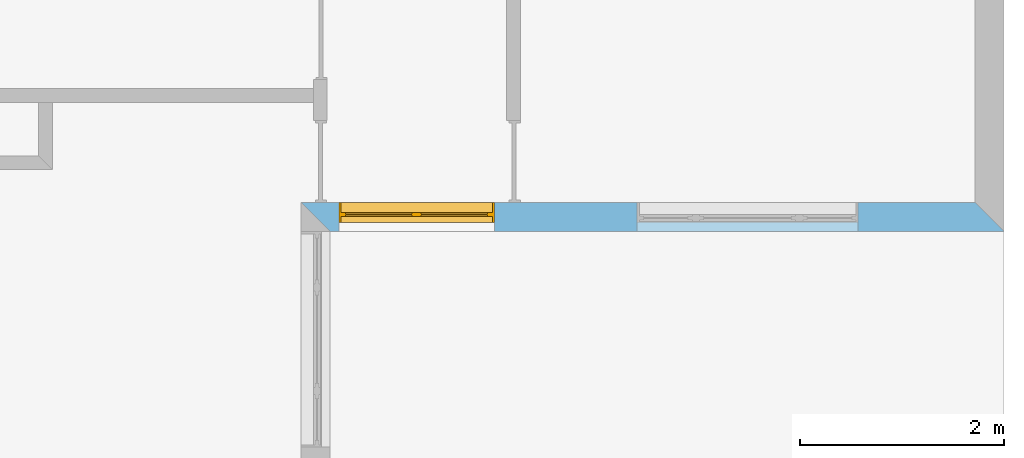
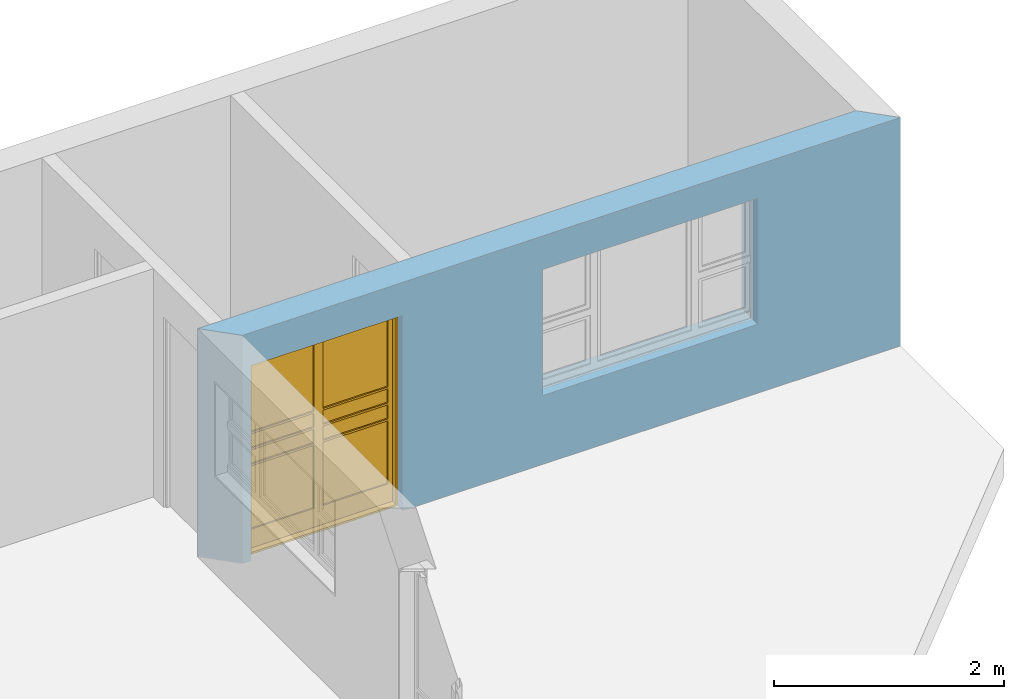
# One storey, part 12 of 15: 1 window, 2 openings, plus 1 element that does not belong to this part.
"""IFC4 building model written with IfcOpenShell, lengths in millimetres."""

from ifc_helpers import new_model, entity, si_unit, converted_unit, frame, origin_with_axes, origin_2d_with_axis, place, context, subcontext, project, spatial, line, indexed_curve, outline, extrude, clip, halfspace, polygons, source, transform, mapped, material, layer, layer_set, layer_usage, type_object, type_shapes, element, fill, save


model = new_model("IFC4")

# Units and contexts
model_context = context("Model", 3, precision=1e-05, world=origin_with_axes())
plan_context = context("Plan", 2, precision=1e-05, world=origin_2d_with_axis())
body_context = subcontext(model_context, "Body", "Model", "MODEL_VIEW")
ifc_project = project(units=[si_unit("VOLUMEUNIT", "CUBIC_METRE"), si_unit("LENGTHUNIT", "METRE", prefix="MILLI"), converted_unit("PLANEANGLEUNIT", "degree", entity("IfcReal", 0.0174532925199433), si_unit("PLANEANGLEUNIT", "RADIAN"), dimensions=[0, 0, 0, 0, 0, 0, 0]), si_unit("AREAUNIT", "SQUARE_METRE")], contexts=[model_context, plan_context])

# Site, building, storey
site_placement = place(None, origin_with_axes())
site = spatial("IfcSite", under=ifc_project, at=site_placement)
building_placement = place(site_placement, origin_with_axes())
building = spatial("IfcBuilding", under=site, at=building_placement, Name="Building")
storey_placement = place(building_placement, origin_with_axes())
storey = spatial("IfcBuildingStorey", under=building, at=storey_placement, Name="EXISTING")

# Wall, openings, window
ifc_material = material()
ifc_layer = layer(ifc_material, 285.0, Name="brick")
ifc_layer_set = layer_set([ifc_layer])
ifc_layer_usage = layer_usage(ifc_layer_set, "AXIS2", "POSITIVE", 0.0)
wall_type = type_object("IfcWallType", Name="285mm Wall", PredefinedType="STANDARD", material=ifc_layer_set)
wall_placement = place(storey_placement, frame((13209.1217041016, 2256.66809082031, 0.0), z_axis=(0.0, 0.0, 1.0), x_axis=(0.999999999999993, 1.19209282445353e-07, 0.0)))
wall = element("IfcWall", 1, at=wall_placement, inside=storey, type_object=wall_type, material=ifc_layer_usage, Name="Wall", context=body_context, shape_type="Clipping", body=[
    clip(clip(extrude(outline(indexed_curve([(0.0, 0.0), (0.0, 285.0), (6894.99959678732, 285.0), (6894.99959678732, 0.0), (0.0, 0.0)], self_intersect=False)), origin_with_axes(), (0.0, 0.0, 1.0), 2425.00019073486), halfspace(frame((284.999847412109, 0.0, 0.0), z_axis=(-0.70710676908493, -0.70710676908493, 0.0), x_axis=(-0.707106781186547, 0.707106781186547, 0.0)), False)), halfspace(frame((6894.99950408936, 0.0, 0.0), z_axis=(0.70710676908493, 0.70710676908493, 0.0), x_axis=(0.707106781186547, -0.707106781186547, 0.0)), False)),
])
shared_shape_1 = source(origin_with_axes(), body_context, "Body", "SweptSolid", [
    extrude(outline(indexed_curve([(0.0, 0.0), (2165.00048828125, 0.0), (2165.00048828125, 1340.00048828125), (0.0, 1340.00048828125)], segments=[line(1, 2, 3, 4, 1)])), frame((-5.96046390910487e-07, -600.0, 0.0), z_axis=(0.0, -1.0, 0.0), x_axis=(1.0, 0.0, 0.0)), (0.0, 0.0, -1.0), 1200.0),
])
opening_1_placement = place(wall_placement, frame((5461.99893951417, 136.110782623295, 730.000019073486), z_axis=(0.0, 0.0, 1.0), x_axis=(-0.999999999999989, 1.50995802528085e-07, 0.0)))
element("IfcOpeningElement", 2, at=opening_1_placement, cuts=wall, Name="Opening", PredefinedType="OPENING", context=body_context, shape_type="MappedRepresentation", body=[
    mapped(shared_shape_1, transform((0.0, 0.0, 0.0), x_axis=(1.0, 0.0, 0.0), y_axis=(0.0, 1.0, 0.0), z_axis=(0.0, 0.0, 1.0), scale=1.0)),
])
shared_shape_2 = source(origin_with_axes(), body_context, "Body", "SweptSolid", [
    extrude(outline(indexed_curve([(0.0, 0.0), (1525.00244140625, 0.0), (1525.00244140625, 2075.0029296875), (0.0, 2075.0029296875)], segments=[line(1, 2, 3, 4, 1)])), frame((1.19209282445354e-07, -600.0, 0.0), z_axis=(0.0, -1.0, 0.0), x_axis=(1.0, 0.0, 0.0)), (0.0, 0.0, -1.0), 1200.0),
])
opening_2_placement = place(wall_placement, frame((1895.00141143799, -33.8461399078334, 0.0), z_axis=(0.0, 0.0, 1.0), x_axis=(-0.999999999999989, 1.50995802528085e-07, 0.0)))
opening_2 = element("IfcOpeningElement", 3, at=opening_2_placement, cuts=wall, PredefinedType="OPENING", context=body_context, shape_type="MappedRepresentation", body=[
    mapped(shared_shape_2, transform((0.0, 0.0, 0.0), x_axis=(1.0, 0.0, 0.0), y_axis=(0.0, 1.0, 0.0), z_axis=(0.0, 0.0, 1.0), scale=1.0)),
])
window_type = type_object("IfcWindowType", Name="Ex.1525x2075", PartitioningType="NOTDEFINED", PredefinedType="WINDOW")
shared_shape_3 = source(origin_with_axes(), body_context, "Body", "Tessellation", [
    polygons([(1525.00061035156, -116.923126220703, 0.0), (1525.00061035156, -116.923126220703, 19.999979019165), (0.000119209282274824, -116.923126220703, 0.0), (0.000119209282274824, -116.923126220703, 19.999979019165), (1525.00061035156, 83.0769729614258, 0.0), (1525.00061035156, 83.0769729614258, 19.999979019165), (0.000119209282274824, 83.0768508911133, 0.0), (0.000119209282274824, 83.0768508911133, 19.999979019165), (0.00202655768953264, -116.923126220703, 19.999979019165), (20.0024833679199, -116.923126220703, 19.999979019165), (0.00202655768953264, -116.923126220703, 2055.00317382812), (20.0024833679199, -116.923126220703, 2055.00317382812), (0.00202655768953264, 83.0769729614258, 19.999979019165), (20.0024833679199, 83.0769729614258, 19.999979019165), (0.00202655768953264, 83.0768508911133, 2055.00317382812), (20.0024833679199, 83.0768508911133, 2055.00317382812), (1505.00207519531, -116.923126220703, 19.999979019165), (1525.00256347656, -116.923126220703, 19.999979019165), (1505.00207519531, -116.923126220703, 2055.00317382812), (1525.00256347656, -116.923126220703, 2055.00317382812), (1505.00207519531, 83.0769729614258, 19.999979019165), (1525.00256347656, 83.0769729614258, 19.999979019165), (1505.00207519531, 83.0768508911133, 2055.00317382812), (1525.00256347656, 83.0768508911133, 2055.00317382812), (1525.00061035156, -116.923126220703, 2055.00317382812), (1525.00061035156, -116.923126220703, 2075.00317382812), (0.000119209282274824, -116.923126220703, 2055.00317382812), (0.000119209282274824, -116.923126220703, 2075.00317382812), (1525.00061035156, 83.0769729614258, 2055.00317382812), (1525.00061035156, 83.0769729614258, 2075.00317382812), (0.000119209282274824, 83.0768508911133, 2055.00317382812), (0.000119209282274824, 83.0768508911133, 2075.00317382812), (65.0006484985352, -16.9231052398682, 2010.00390625), (20.0005760192871, -16.9231052398682, 2010.00390625), (65.0006484985352, -16.9231052398682, 220.002532958984), (20.0005760192871, -16.9231052398682, 220.002532958984), (65.0006484985352, 23.0769119262695, 2010.00390625), (20.0005760192871, 23.0769119262695, 2010.00390625), (65.0006484985352, 23.0769119262695, 220.002532958984), (20.0005760192871, 23.0769119262695, 220.002532958984), (762.500854492188, -16.9229869842529, 20.0024833679199), (762.500854492188, -16.9229869842529, 220.00146484375), (20.0005760192871, -16.9231052398682, 20.0034370422363), (20.0005760192871, -16.9231052398682, 220.002410888672), (762.500854492188, 23.0770320892334, 20.0024833679199), (762.500854492188, 23.0770320892334, 220.00146484375), (20.0005760192871, 23.0769119262695, 20.0034370422363), (20.0005760192871, 23.0769119262695, 220.002410888672), (1505.00109863281, -16.9231052398682, 2010.00366210938), (1460.001953125, -16.9231052398682, 2010.00366210938), (1505.00109863281, -16.9231052398682, 220.002288818359), (1460.001953125, -16.9231052398682, 220.002288818359), (1505.00109863281, 23.0769119262695, 2010.00366210938), (1460.001953125, 23.0769119262695, 2010.00366210938), (1505.00109863281, 23.0769119262695, 220.002288818359), (1460.001953125, 23.0769119262695, 220.002288818359), (762.502746582031, -16.9231052398682, 2010.00341796875), (717.503601074219, -16.9231052398682, 2010.00341796875), (762.502746582031, -16.9231052398682, 220.002410888672), (717.503601074219, -16.9231052398682, 220.002410888672), (762.502746582031, 23.0769119262695, 2010.00341796875), (717.503601074219, 23.0769119262695, 2010.00341796875), (762.502746582031, 23.0769119262695, 220.002410888672), (717.503601074219, 23.0769119262695, 220.002410888672), (807.499938964844, -16.9231052398682, 2010.00341796875), (762.501770019531, -16.9231052398682, 2010.00341796875), (807.499938964844, -16.9231052398682, 220.002410888672), (762.501770019531, -16.9231052398682, 220.002410888672), (807.499938964844, 23.0769119262695, 2010.00341796875), (762.501770019531, 23.0769119262695, 2010.00341796875), (807.499938964844, 23.0769119262695, 220.002410888672), (762.501770019531, 23.0769119262695, 220.002410888672), (1505.00109863281, -16.9229869842529, 20.0024833679199), (1505.00109863281, -16.9229869842529, 220.00146484375), (762.502746582031, -16.9231052398682, 20.0034370422363), (762.502746582031, -16.9231052398682, 220.002410888672), (1505.00109863281, 23.0770320892334, 20.0024833679199), (1505.00109863281, 23.0770320892334, 220.00146484375), (762.502746582031, 23.0769119262695, 20.0034370422363), (762.502746582031, 23.0769119262695, 220.002410888672), (762.500854492188, -16.9229869842529, 2010.00268554688), (762.500854492188, -16.9229869842529, 2055.00244140625), (20.0005760192871, -16.9231052398682, 2010.00366210938), (20.0005760192871, -16.9231052398682, 2055.00317382812), (762.500854492188, 23.0770320892334, 2010.00268554688), (762.500854492188, 23.0770320892334, 2055.00244140625), (20.0005760192871, 23.0769119262695, 2010.00366210938), (20.0005760192871, 23.0769119262695, 2055.00317382812), (1505.00109863281, -16.9229869842529, 2010.00268554688), (1505.00109863281, -16.9229869842529, 2055.00244140625), (762.502746582031, -16.9231052398682, 2010.00366210938), (762.502746582031, -16.9231052398682, 2055.00317382812), (1505.00109863281, 23.0770320892334, 2010.00268554688), (1505.00109863281, 23.0770320892334, 2055.00244140625), (762.502746582031, 23.0769119262695, 2010.00366210938), (762.502746582031, 23.0769119262695, 2055.00317382812), (717.500732421875, -16.9229869842529, 1230.00207519531), (717.500732421875, -16.9229869842529, 1250.00158691406), (64.9987411499023, -16.9231052398682, 1230.00244140625), (64.9987411499023, -16.9231052398682, 1250.00207519531), (717.500732421875, 23.0770320892334, 1230.00207519531), (717.500732421875, 23.0770320892334, 1250.00158691406), (64.9987411499023, 23.0769119262695, 1230.00244140625), (64.9987411499023, 23.0769119262695, 1250.00207519531), (1460.0009765625, -16.9229869842529, 1230.00207519531), (1460.0009765625, -16.9229869842529, 1250.00158691406), (807.499938964844, -16.9231052398682, 1230.00244140625), (807.499938964844, -16.9231052398682, 1250.00207519531), (1460.0009765625, 23.0770320892334, 1230.00207519531), (1460.0009765625, 23.0770320892334, 1250.00158691406), (807.499938964844, 23.0769119262695, 1230.00244140625), (807.499938964844, 23.0769119262695, 1250.00207519531), (717.500732421875, -16.9229869842529, 1060.00219726562), (717.500732421875, -16.9229869842529, 1080.00158691406), (64.9987411499023, -16.9231052398682, 1060.00244140625), (64.9987411499023, -16.9231052398682, 1080.00207519531), (717.500732421875, 23.0770320892334, 1060.00219726562), (717.500732421875, 23.0770320892334, 1080.00158691406), (64.9987411499023, 23.0769119262695, 1060.00244140625), (64.9987411499023, 23.0769119262695, 1080.00207519531), (1460.0009765625, -16.9229869842529, 1060.00219726562), (1460.0009765625, -16.9229869842529, 1080.00158691406), (807.499938964844, -16.9231052398682, 1060.00244140625), (807.499938964844, -16.9231052398682, 1080.00207519531), (1460.0009765625, 23.0770320892334, 1060.00219726562), (1460.0009765625, 23.0770320892334, 1080.00158691406), (807.499938964844, 23.0769119262695, 1060.00244140625), (807.499938964844, 23.0769119262695, 1080.00207519531), (717.500732421875, -16.9229869842529, 890.002197265625), (717.500732421875, -16.9229869842529, 910.001708984375), (64.9987411499023, -16.9231052398682, 890.00244140625), (64.9987411499023, -16.9231052398682, 910.002197265625), (717.500732421875, 23.0770320892334, 890.002197265625), (717.500732421875, 23.0770320892334, 910.001708984375), (64.9987411499023, 23.0769119262695, 890.00244140625), (64.9987411499023, 23.0769119262695, 910.002197265625), (1460.0009765625, -16.9229869842529, 890.002197265625), (1460.0009765625, -16.9229869842529, 910.001708984375), (807.499938964844, -16.9231052398682, 890.00244140625), (807.499938964844, -16.9231052398682, 910.002197265625), (1460.0009765625, 23.0770320892334, 890.002197265625), (1460.0009765625, 23.0770320892334, 910.001708984375), (807.499938964844, 23.0769119262695, 890.00244140625), (807.499938964844, 23.0769119262695, 910.002197265625), (717.501708984375, -1.92306184768677, 2010.00341796875), (65.0006484985352, -1.92306184768677, 2010.00341796875), (717.500732421875, -1.92306184768677, 1250.00207519531), (65.0006484985352, -1.92306184768677, 1250.00207519531), (717.501708984375, 8.07692813873291, 2010.00341796875), (65.0006484985352, 8.07692813873291, 2010.00341796875), (717.500732421875, 8.07692813873291, 1250.00207519531), (65.0006484985352, 8.07692813873291, 1250.00207519531), (717.501708984375, -1.92306184768677, 890.001953125), (65.0006484985352, -1.92306184768677, 890.001953125), (717.500732421875, -1.92306184768677, 220.001998901367), (65.0006484985352, -1.92306184768677, 220.002059936523), (717.501708984375, 8.07692813873291, 890.001953125), (65.0006484985352, 8.07692813873291, 890.001953125), (717.500732421875, 8.07692813873291, 220.001998901367), (65.0006484985352, 8.07692813873291, 220.002059936523), (717.501708984375, -1.92306184768677, 1230.001953125), (65.0006484985352, -1.92306184768677, 1230.001953125), (717.500732421875, -1.92306184768677, 1080.00158691406), (65.0006484985352, -1.92306184768677, 1080.00158691406), (717.501708984375, 8.07692813873291, 1230.001953125), (65.0006484985352, 8.07692813873291, 1230.001953125), (717.500732421875, 8.07692813873291, 1080.00158691406), (65.0006484985352, 8.07692813873291, 1080.00158691406), (1460.0009765625, -1.92306184768677, 2010.00341796875), (807.499938964844, -1.92306184768677, 2010.00341796875), (1460.0009765625, -1.92306184768677, 1250.00207519531), (807.499938964844, -1.92306184768677, 1250.00207519531), (1460.0009765625, 8.07692813873291, 2010.00341796875), (807.499938964844, 8.07692813873291, 2010.00341796875), (1460.0009765625, 8.07692813873291, 1250.00207519531), (807.499938964844, 8.07692813873291, 1250.00207519531), (1460.0009765625, -1.92306184768677, 890.001953125), (807.499938964844, -1.92306184768677, 890.001953125), (1460.0009765625, -1.92306184768677, 220.001998901367), (807.499938964844, -1.92306184768677, 220.002059936523), (1460.0009765625, 8.07692813873291, 890.001953125), (807.499938964844, 8.07692813873291, 890.001953125), (1460.0009765625, 8.07692813873291, 220.001998901367), (807.499938964844, 8.07692813873291, 220.002059936523), (1460.0009765625, -1.92306184768677, 1230.001953125), (807.499938964844, -1.92306184768677, 1230.001953125), (1460.00012207031, -1.92306184768677, 1080.00158691406), (807.499938964844, -1.92306184768677, 1080.00158691406), (1460.0009765625, 8.07692813873291, 1230.001953125), (807.499938964844, 8.07692813873291, 1230.001953125), (1460.00012207031, 8.07692813873291, 1080.00158691406), (807.499938964844, 8.07692813873291, 1080.00158691406), (717.501708984375, -1.92306184768677, 1060.00256347656), (65.0006484985352, -1.92306184768677, 1060.00256347656), (717.500732421875, -1.92306184768677, 910.002197265625), (65.0006484985352, -1.92306184768677, 910.002197265625), (717.501708984375, 8.07692813873291, 1060.00256347656), (65.0006484985352, 8.07692813873291, 1060.00256347656), (717.500732421875, 8.07692813873291, 910.002197265625), (65.0006484985352, 8.07692813873291, 910.002197265625), (1460.0009765625, -1.92306184768677, 1060.00256347656), (807.499938964844, -1.92306184768677, 1060.00256347656), (1460.00012207031, -1.92306184768677, 910.002197265625), (807.499938964844, -1.92306184768677, 910.002197265625), (1460.0009765625, 8.07692813873291, 1060.00256347656), (807.499938964844, 8.07692813873291, 1060.00256347656), (1460.00012207031, 8.07692813873291, 910.002197265625), (807.499938964844, 8.07692813873291, 910.002197265625)], [[[1, 2, 4, 3]], [[3, 4, 8, 7]], [[7, 8, 6, 5]], [[5, 6, 2, 1]], [[3, 7, 5, 1]], [[8, 4, 2, 6]], [[9, 10, 12, 11]], [[11, 12, 16, 15]], [[15, 16, 14, 13]], [[13, 14, 10, 9]], [[11, 15, 13, 9]], [[16, 12, 10, 14]], [[17, 18, 20, 19]], [[19, 20, 24, 23]], [[23, 24, 22, 21]], [[21, 22, 18, 17]], [[19, 23, 21, 17]], [[24, 20, 18, 22]], [[25, 26, 28, 27]], [[27, 28, 32, 31]], [[31, 32, 30, 29]], [[29, 30, 26, 25]], [[27, 31, 29, 25]], [[32, 28, 26, 30]], [[33, 34, 36, 35]], [[35, 36, 40, 39]], [[39, 40, 38, 37]], [[37, 38, 34, 33]], [[35, 39, 37, 33]], [[40, 36, 34, 38]], [[41, 42, 44, 43]], [[43, 44, 48, 47]], [[47, 48, 46, 45]], [[45, 46, 42, 41]], [[43, 47, 45, 41]], [[48, 44, 42, 46]], [[49, 50, 52, 51]], [[51, 52, 56, 55]], [[55, 56, 54, 53]], [[53, 54, 50, 49]], [[51, 55, 53, 49]], [[56, 52, 50, 54]], [[57, 58, 60, 59]], [[59, 60, 64, 63]], [[63, 64, 62, 61]], [[61, 62, 58, 57]], [[59, 63, 61, 57]], [[64, 60, 58, 62]], [[65, 66, 68, 67]], [[67, 68, 72, 71]], [[71, 72, 70, 69]], [[69, 70, 66, 65]], [[67, 71, 69, 65]], [[72, 68, 66, 70]], [[73, 74, 76, 75]], [[75, 76, 80, 79]], [[79, 80, 78, 77]], [[77, 78, 74, 73]], [[75, 79, 77, 73]], [[80, 76, 74, 78]], [[81, 82, 84, 83]], [[83, 84, 88, 87]], [[87, 88, 86, 85]], [[85, 86, 82, 81]], [[83, 87, 85, 81]], [[88, 84, 82, 86]], [[89, 90, 92, 91]], [[91, 92, 96, 95]], [[95, 96, 94, 93]], [[93, 94, 90, 89]], [[91, 95, 93, 89]], [[96, 92, 90, 94]], [[97, 98, 100, 99]], [[99, 100, 104, 103]], [[103, 104, 102, 101]], [[101, 102, 98, 97]], [[99, 103, 101, 97]], [[104, 100, 98, 102]], [[105, 106, 108, 107]], [[107, 108, 112, 111]], [[111, 112, 110, 109]], [[109, 110, 106, 105]], [[107, 111, 109, 105]], [[112, 108, 106, 110]], [[113, 114, 116, 115]], [[115, 116, 120, 119]], [[119, 120, 118, 117]], [[117, 118, 114, 113]], [[115, 119, 117, 113]], [[120, 116, 114, 118]], [[121, 122, 124, 123]], [[123, 124, 128, 127]], [[127, 128, 126, 125]], [[125, 126, 122, 121]], [[123, 127, 125, 121]], [[128, 124, 122, 126]], [[129, 130, 132, 131]], [[131, 132, 136, 135]], [[135, 136, 134, 133]], [[133, 134, 130, 129]], [[131, 135, 133, 129]], [[136, 132, 130, 134]], [[137, 138, 140, 139]], [[139, 140, 144, 143]], [[143, 144, 142, 141]], [[141, 142, 138, 137]], [[139, 143, 141, 137]], [[144, 140, 138, 142]], [[145, 146, 148, 147]], [[147, 148, 152, 151]], [[151, 152, 150, 149]], [[149, 150, 146, 145]], [[147, 151, 149, 145]], [[152, 148, 146, 150]], [[153, 154, 156, 155]], [[155, 156, 160, 159]], [[159, 160, 158, 157]], [[157, 158, 154, 153]], [[155, 159, 157, 153]], [[160, 156, 154, 158]], [[161, 162, 164, 163]], [[163, 164, 168, 167]], [[167, 168, 166, 165]], [[165, 166, 162, 161]], [[163, 167, 165, 161]], [[168, 164, 162, 166]], [[169, 170, 172, 171]], [[171, 172, 176, 175]], [[175, 176, 174, 173]], [[173, 174, 170, 169]], [[171, 175, 173, 169]], [[176, 172, 170, 174]], [[177, 178, 180, 179]], [[179, 180, 184, 183]], [[183, 184, 182, 181]], [[181, 182, 178, 177]], [[179, 183, 181, 177]], [[184, 180, 178, 182]], [[185, 186, 188, 187]], [[187, 188, 192, 191]], [[191, 192, 190, 189]], [[189, 190, 186, 185]], [[187, 191, 189, 185]], [[192, 188, 186, 190]], [[193, 194, 196, 195]], [[195, 196, 200, 199]], [[199, 200, 198, 197]], [[197, 198, 194, 193]], [[195, 199, 197, 193]], [[200, 196, 194, 198]], [[201, 202, 204, 203]], [[203, 204, 208, 207]], [[207, 208, 206, 205]], [[205, 206, 202, 201]], [[203, 207, 205, 201]], [[208, 204, 202, 206]]], closed=True),
])
type_shapes(window_type, [shared_shape_3])
window_placement = place(opening_2_placement, frame((0.000964127488956024, -201.922429203797, 0.0), z_axis=(0.0, 0.0, 1.0), x_axis=(0.999999999999936, -3.57627847336035e-07, 0.0)))
window = element("IfcWindow", 4, at=window_placement, inside=storey, type_object=window_type, Name="Window", context=body_context, shape_type="MappedRepresentation", body=[
    mapped(shared_shape_3, transform((0.0, 0.0, 0.0), x_axis=(1.0, 0.0, 0.0), y_axis=(0.0, 1.0, 0.0), z_axis=(0.0, 0.0, 1.0), scale=1.0)),
])
fill(opening_2, window)

save(model, "model.ifc")
